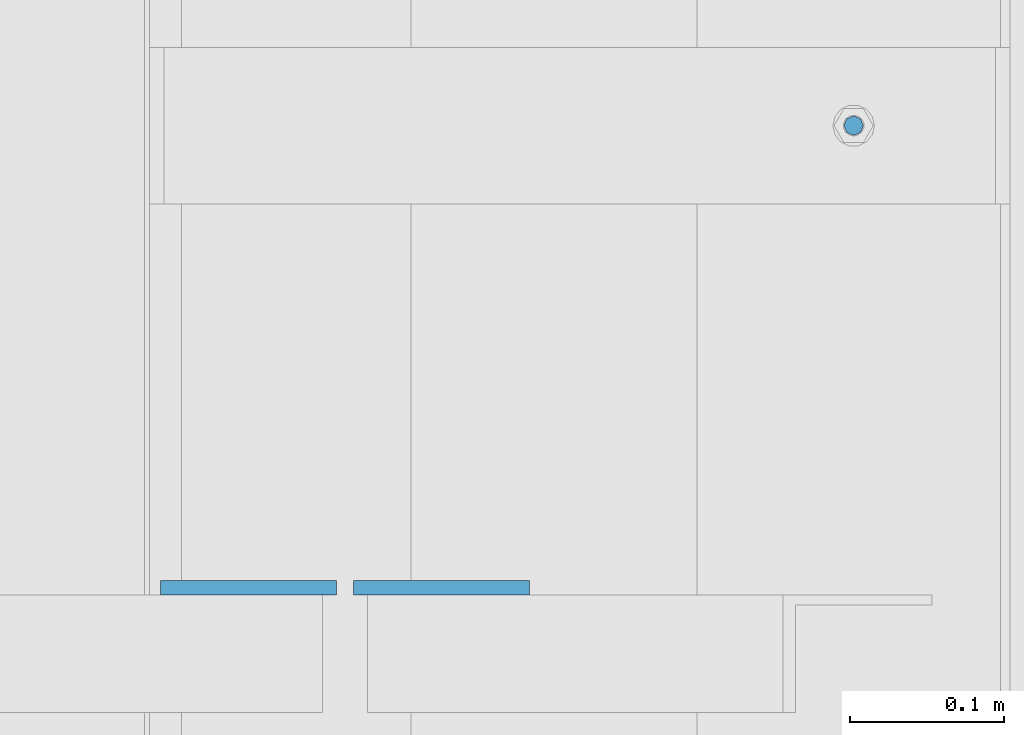
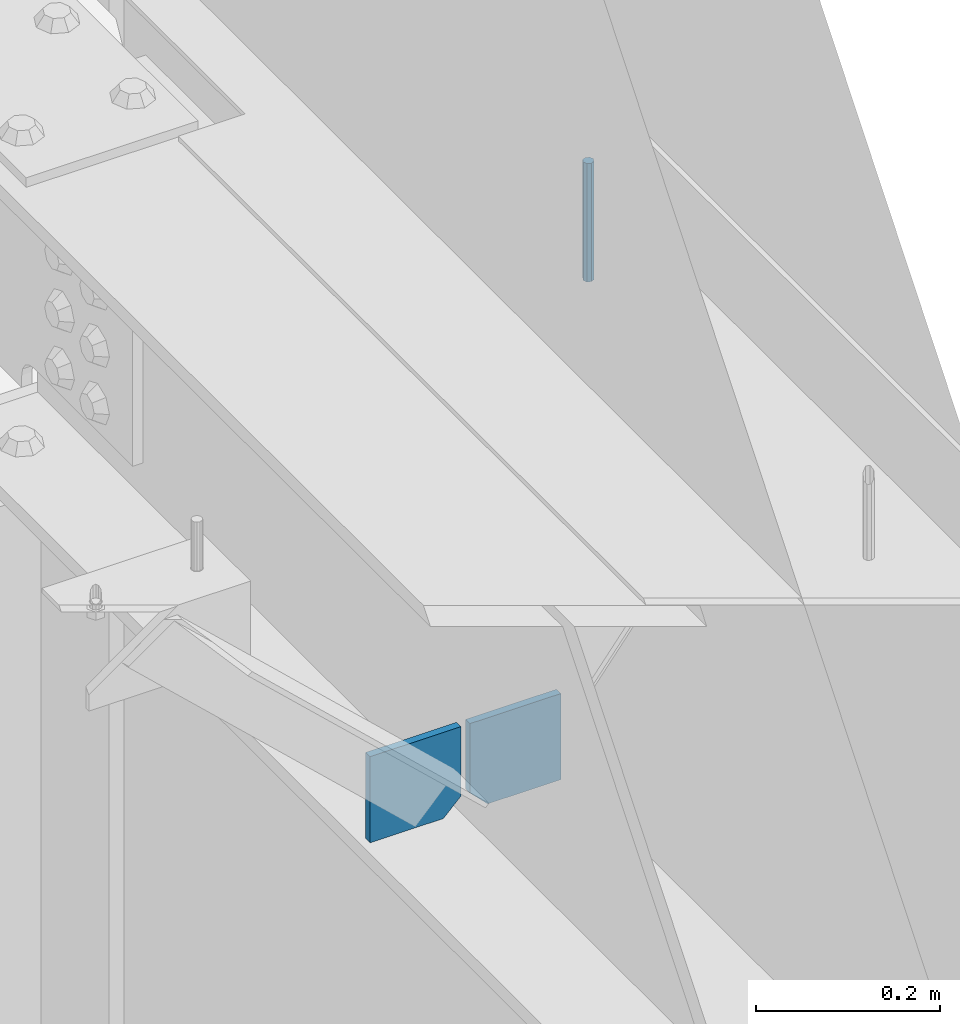
# One storey, part 464 of 1179: 3 columns, 1 element without a shape of its own.
"""IFC2X3 building model written with IfcOpenShell, lengths in millimetres."""

from ifc_helpers import new_model, si_unit, frame, origin_with_axes, place, context, subcontext, project, spatial, faceted_brep, material, type_object, element, aggregate, save


model = new_model("IFC2X3")

# Units and contexts
model_context = context("Model", 3, precision=1e-05, world=origin_with_axes())
body_context = subcontext(model_context, "Body", "Model", "MODEL_VIEW")
ifc_project = project(units=[si_unit("LENGTHUNIT", "METRE", prefix="MILLI"), si_unit("AREAUNIT", "SQUARE_METRE"), si_unit("VOLUMEUNIT", "CUBIC_METRE"), si_unit("MASSUNIT", "GRAM", prefix="KILO"), si_unit("TIMEUNIT", "SECOND"), si_unit("PLANEANGLEUNIT", "RADIAN"), si_unit("SOLIDANGLEUNIT", "STERADIAN"), si_unit("THERMODYNAMICTEMPERATUREUNIT", "DEGREE_CELSIUS"), si_unit("LUMINOUSINTENSITYUNIT", "LUMEN")], contexts=[model_context])

# Site, building, storey
site_placement = place(None, origin_with_axes())
site = spatial("IfcSite", under=ifc_project, at=site_placement, CompositionType="ELEMENT")
building_placement = place(site_placement, origin_with_axes())
building = spatial("IfcBuilding", under=site, at=building_placement, Name="Undefined", CompositionType="ELEMENT")
storey_placement = place(building_placement, origin_with_axes())
storey = spatial("IfcBuildingStorey", under=building, at=storey_placement, Name="Undefined", CompositionType="ELEMENT", Elevation=0.0)

# Assembly, columns
assembly_placement = place(storey_placement, origin_with_axes())
assembly = element("IfcElementAssembly", 1, at=assembly_placement, inside=storey, Name="BEAM", AssemblyPlace="NOTDEFINED", PredefinedType="RIGID_FRAME")
ifc_material_1 = material(Name="STEEL/A36")
column_type_1 = type_object("IfcColumnType", PredefinedType="NOTDEFINED")
column_1_placement = place(assembly_placement, frame((24245.09375, 25887.3625, 3702.05), z_axis=(1.0, 0.0, 0.0), x_axis=(0.0, 0.0, 1.0)))
column_1 = element("IfcColumn", 2, at=column_1_placement, type_object=column_type_1, material=ifc_material_1, Name="PLATE", context=body_context, shape_type="Brep", body=[
    faceted_brep([(22.2250000000004, 4.76250000000073, 57.1500000000015), (0.0, 4.76250000000073, 34.9249999999993), (0.0, -4.76250000000073, 34.9249999999993), (22.2250000000004, -4.76250000000073, 57.1500000000015), (114.300000000001, 4.76250000000073, 57.1500000000015), (114.300000000001, 4.76250000000073, -57.1500000000015), (0.0, 4.76250000000073, -57.1500000000015), (114.300000000001, -4.76250000000073, 57.1500000000015), (0.0, -4.76250000000073, -57.1500000000015), (114.300000000001, -4.76250000000073, -57.1500000000015)], [[[0, 1, 2, 3]], [[4, 5, 6, 1, 0]], [[7, 4, 0, 3]], [[8, 9, 7, 3, 2]], [[8, 6, 5, 9]], [[7, 9, 5, 4]], [[6, 8, 2, 1]]]),
])
column_2_placement = place(assembly_placement, frame((24370.50625, 25887.3625, 3702.05), z_axis=(-1.0, 0.0, 0.0), x_axis=(0.0, 0.0, 1.0)))
column_2 = element("IfcColumn", 3, at=column_2_placement, type_object=column_type_1, material=ifc_material_1, Name="PLATE", context=body_context, shape_type="Brep", body=[
    faceted_brep([(22.2250000000004, 4.76250000000073, 57.1500000000015), (0.0, 4.76250000000073, 34.9249999999993), (0.0, -4.76250000000073, 34.9249999999993), (22.2250000000004, -4.76250000000073, 57.1500000000015), (114.300000000001, 4.76250000000073, 57.1500000000015), (114.300000000001, 4.76250000000073, -57.1500000000015), (0.0, 4.76250000000073, -57.1500000000015), (114.300000000001, -4.76250000000073, 57.1500000000015), (0.0, -4.76250000000073, -57.1500000000015), (114.300000000001, -4.76250000000073, -57.1500000000015)], [[[0, 1, 2, 3]], [[4, 5, 6, 1, 0]], [[7, 4, 0, 3]], [[8, 9, 7, 3, 2]], [[8, 6, 5, 9]], [[7, 9, 5, 4]], [[6, 8, 2, 1]]]),
])
ifc_material_2 = material(Name="STEEL/A307")
column_type_2 = type_object("IfcColumnType", PredefinedType="NOTDEFINED")
column_3_placement = place(assembly_placement, frame((24638.0, 26187.4, 4108.45), z_axis=(0.0, 1.0, 0.0), x_axis=(0.0, 0.0, 1.0)))
column_3 = element("IfcColumn", 4, at=column_3_placement, type_object=column_type_2, material=ifc_material_2, Name="THREADED ROD", context=body_context, shape_type="Brep", body=[
    faceted_brep([(0.0, -6.34999999999854, 0.0), (0.0, -4.49012806053361, -4.49012806053452), (157.162499999999, -4.49012806053361, -4.49012806053361), (157.162499999999, -6.34999999999854, 0.0), (0.0, 0.0, -6.34999999999991), (157.162499999999, 0.0, -6.34999999999854), (0.0, 4.49012806053361, -4.49012806053452), (157.162499999999, 4.49012806053361, -4.49012806053361), (0.0, 6.34999999999854, 0.0), (157.162499999999, 6.34999999999854, 0.0), (0.0, 4.49012806053361, 4.49012806053452), (157.162499999999, 4.49012806053361, 4.49012806053361), (0.0, 0.0, 6.34999999999991), (157.162499999999, 0.0, 6.34999999999854), (0.0, -4.49012806053361, 4.49012806053452), (157.162499999999, -4.49012806053361, 4.49012806053361)], [[[0, 1, 2, 3]], [[1, 4, 5, 2]], [[4, 6, 7, 5]], [[6, 8, 9, 7]], [[8, 10, 11, 9]], [[10, 12, 13, 11]], [[12, 14, 15, 13]], [[14, 0, 3, 15]], [[5, 7, 9, 11, 13, 15, 3, 2]], [[14, 12, 10, 8, 6, 4, 1, 0]]]),
])
aggregate(assembly, [column_3, column_1, column_2])

save(model, "model.ifc")
